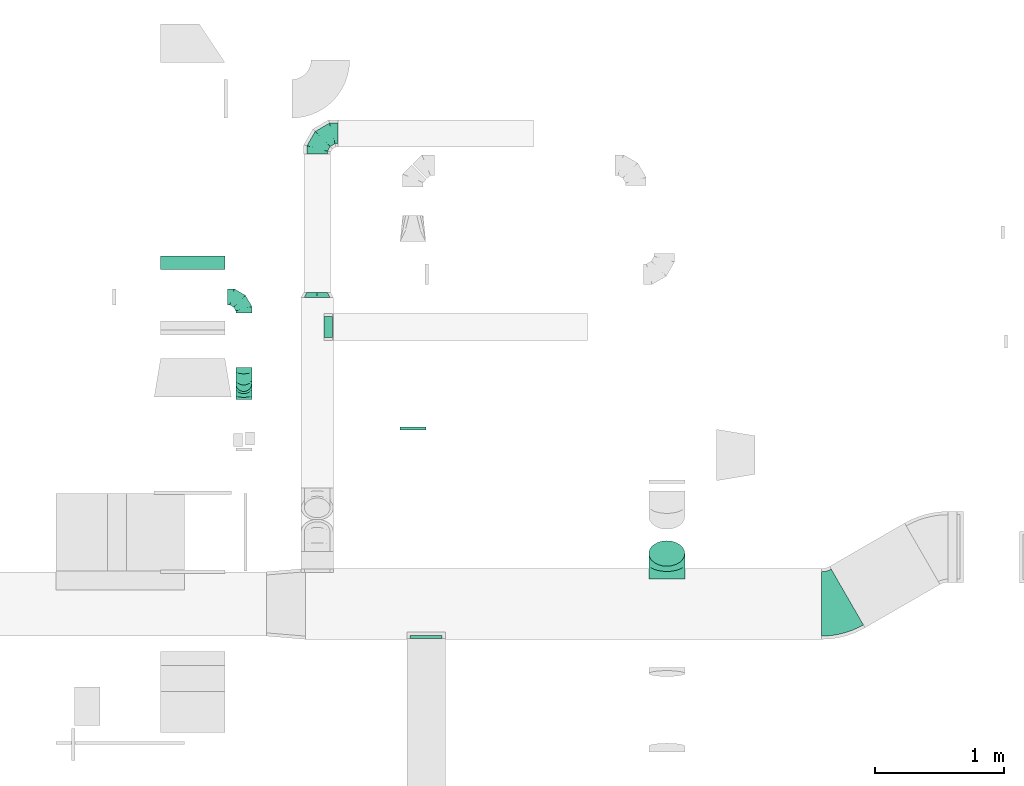
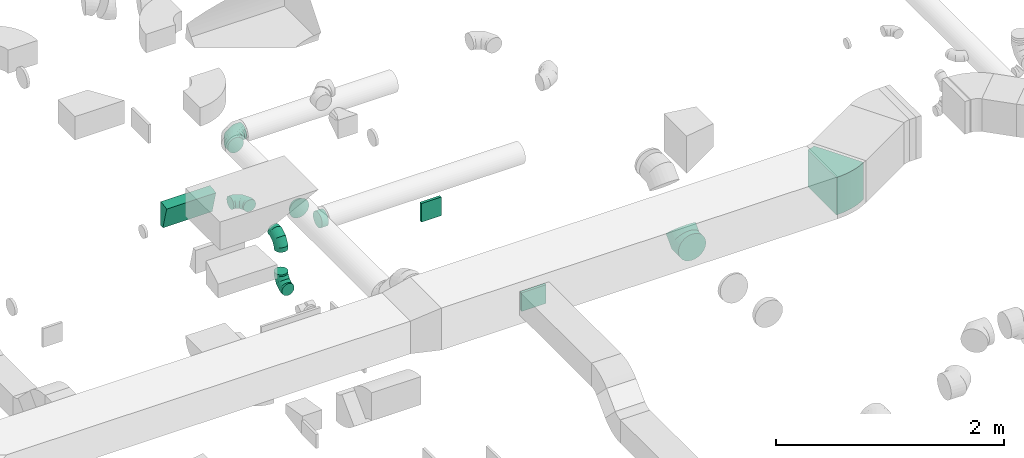
# One storey, part 43 of 62: 11 flow fittings.
"""IFC2X3 building model written with IfcOpenShell, lengths in millimetres."""

from ifc_helpers import new_model, entity, si_unit, converted_unit, derived_unit, direction, frame, frame_2d, origin, origin_2d_with_axis, place, context, subcontext, project, spatial, polyline, circle_curve, parameter, trimmed, segment, composite_curve, rectangle, outline, extrude, faceted_brep, source, transform, mapped, material, type_object, type_shapes, element, save


model = new_model("IFC2X3")

# Units and contexts
model_context = context("Model", 3, precision=0.01, world=origin(), true_north=direction((6.12303176911189e-17, 1.0)))
body_context = subcontext(model_context, "Body", "Model", "MODEL_VIEW")
ifc_project = project(units=[si_unit("LENGTHUNIT", "METRE", prefix="MILLI"), si_unit("AREAUNIT", "SQUARE_METRE"), si_unit("VOLUMEUNIT", "CUBIC_METRE"), converted_unit("PLANEANGLEUNIT", "DEGREE", entity("IfcRatioMeasure", 0.0174532925199433), si_unit("PLANEANGLEUNIT", "RADIAN"), dimensions=[0, 0, 0, 0, 0, 0, 0]), si_unit("MASSUNIT", "GRAM", prefix="KILO"), derived_unit("MASSDENSITYUNIT", [(si_unit("MASSUNIT", "GRAM", prefix="KILO"), 1), (si_unit("LENGTHUNIT", "METRE"), -3)]), derived_unit("MOMENTOFINERTIAUNIT", [(si_unit("LENGTHUNIT", "METRE"), 4)]), si_unit("TIMEUNIT", "SECOND"), si_unit("FREQUENCYUNIT", "HERTZ"), si_unit("THERMODYNAMICTEMPERATUREUNIT", "DEGREE_CELSIUS"), derived_unit("THERMALTRANSMITTANCEUNIT", [(si_unit("MASSUNIT", "GRAM", prefix="KILO"), 1), (si_unit("THERMODYNAMICTEMPERATUREUNIT", "KELVIN"), -1), (si_unit("TIMEUNIT", "SECOND"), -3)]), derived_unit("VOLUMETRICFLOWRATEUNIT", [(si_unit("LENGTHUNIT", "METRE"), 3), (si_unit("TIMEUNIT", "SECOND"), -1)]), derived_unit("MASSFLOWRATEUNIT", [(si_unit("MASSUNIT", "GRAM", prefix="KILO"), 1), (si_unit("TIMEUNIT", "SECOND"), -1)]), derived_unit("ROTATIONALFREQUENCYUNIT", [(si_unit("TIMEUNIT", "SECOND"), -1)]), si_unit("ELECTRICCURRENTUNIT", "AMPERE"), si_unit("ELECTRICVOLTAGEUNIT", "VOLT"), si_unit("POWERUNIT", "WATT"), si_unit("FORCEUNIT", "NEWTON", prefix="KILO"), si_unit("ILLUMINANCEUNIT", "LUX"), si_unit("LUMINOUSFLUXUNIT", "LUMEN"), si_unit("LUMINOUSINTENSITYUNIT", "CANDELA"), derived_unit("USERDEFINED", [(si_unit("MASSUNIT", "GRAM", prefix="KILO"), -1), (si_unit("LENGTHUNIT", "METRE"), -2), (si_unit("TIMEUNIT", "SECOND"), 3), (si_unit("LUMINOUSFLUXUNIT", "LUMEN"), 1)]), derived_unit("LINEARVELOCITYUNIT", [(si_unit("LENGTHUNIT", "METRE"), 1), (si_unit("TIMEUNIT", "SECOND"), -1)]), si_unit("PRESSUREUNIT", "PASCAL"), derived_unit("USERDEFINED", [(si_unit("LENGTHUNIT", "METRE"), -2), (si_unit("MASSUNIT", "GRAM", prefix="KILO"), 1), (si_unit("TIMEUNIT", "SECOND"), -2)]), derived_unit("LINEARFORCEUNIT", [(si_unit("MASSUNIT", "GRAM", prefix="KILO"), 1), (si_unit("LENGTHUNIT", "METRE"), 1), (si_unit("TIMEUNIT", "SECOND"), -2), (si_unit("LENGTHUNIT", "METRE"), -1)]), derived_unit("PLANARFORCEUNIT", [(si_unit("MASSUNIT", "GRAM", prefix="KILO"), 1), (si_unit("LENGTHUNIT", "METRE"), 1), (si_unit("TIMEUNIT", "SECOND"), -2), (si_unit("LENGTHUNIT", "METRE"), -2)])], contexts=[model_context])

# Site, building, storey
site_placement = place(None, origin())
site = spatial("IfcSite", under=ifc_project, at=site_placement, CompositionType="ELEMENT")
building_placement = place(site_placement, origin())
building = spatial("IfcBuilding", under=site, at=building_placement, CompositionType="ELEMENT")
storey_placement = place(building_placement, frame((0.0, 0.0, 24000.0)))
storey = spatial("IfcBuildingStorey", under=building, at=storey_placement, CompositionType="ELEMENT", Elevation=24000.0)

# Flow fittings
ifc_material = material()
duct_fitting_type_1 = type_object("IfcDuctFittingType", PredefinedType="NOTDEFINED", material=ifc_material)
shared_shape_1 = source(origin(), body_context, "Body", "SweptSolid", [
    extrude(rectangle(XDim=26.096000000009, YDim=250.0, at=origin_2d_with_axis()), frame((6.95, 0.0, -100.0)), (0.0, 0.0, 1.0), 200.0),
])
type_shapes(duct_fitting_type_1, [shared_shape_1])
flow_fitting_1_placement = place(storey_placement, frame((55179.59, 8674.98, 3550.0), z_axis=(0.0, 0.0, -1.0), x_axis=(0.0, -1.0, 0.0)))
element("IfcFlowFitting", 1, at=flow_fitting_1_placement, inside=storey, type_object=duct_fitting_type_1, material=ifc_material, context=body_context, shape_type="MappedRepresentation", body=[
    mapped(shared_shape_1, transform((0.0, 0.0, 0.0), scale=1.0)),
])
duct_fitting_type_2 = type_object("IfcDuctFittingType", PredefinedType="NOTDEFINED", material=ifc_material)
shared_shape_2 = source(origin(), body_context, "Body", "SweptSolid", [
    extrude(rectangle(XDim=200.0, YDim=26.0960000001364, at=origin_2d_with_axis()), frame((6.95, 0.0, -100.0), z_axis=(0.0, 0.0, 1.0), x_axis=(0.0, -1.0, 0.0)), (0.0, 0.0, 1.0), 200.0),
])
type_shapes(duct_fitting_type_2, [shared_shape_2])
flow_fitting_2_placement = place(storey_placement, frame((55077.37, 10282.41, 3550.0), z_axis=(0.0, 0.0, -1.0), x_axis=(0.0, 1.0, 0.0)))
element("IfcFlowFitting", 2, at=flow_fitting_2_placement, inside=storey, type_object=duct_fitting_type_2, material=ifc_material, context=body_context, shape_type="MappedRepresentation", body=[
    mapped(shared_shape_2, transform((0.0, 0.0, 0.0), scale=1.0)),
])
duct_fitting_type_3 = type_object("IfcDuctFittingType", PredefinedType="NOTDEFINED", material=ifc_material)
shared_shape_3 = source(origin(), body_context, "Body", "Brep", [
    faceted_brep([(-160.0, 0.0, -80.0), (-160.0, -20.71, -77.27), (-160.0, -40.0, -69.28), (-160.0, -56.57, -56.57), (-160.0, -69.28, -40.0), (-160.0, -77.27, -20.71), (-160.0, -80.0, 0.0), (-160.0, -77.27, 20.71), (-160.0, -69.28, 40.0), (-160.0, -56.57, 56.57), (-160.0, -40.0, 69.28), (-160.0, -20.71, 77.27), (-160.0, 0.0, 80.0), (-160.0, 20.71, 77.27), (-160.0, 40.0, 69.28), (-160.0, 56.57, 56.57), (-160.0, 69.28, 40.0), (-160.0, 77.27, 20.71), (-160.0, 80.0, 0.0), (-160.0, 77.27, -20.71), (-160.0, 69.28, -40.0), (-160.0, 56.57, -56.57), (-160.0, 40.0, -69.28), (-160.0, 20.71, -77.27), (-122.68, 20.71, 77.27), (-127.85, 40.0, 69.28), (-117.13, 0.0, 80.0), (-132.29, 56.57, 56.57), (-137.83, 77.27, 20.71), (-138.56, 80.0, 0.0), (-135.69, 69.28, 40.0), (-135.69, 69.28, -40.0), (-132.29, 56.57, -56.57), (-137.83, 77.27, -20.71), (-122.68, 20.71, -77.27), (-117.13, 0.0, -80.0), (-127.85, 40.0, -69.28), (-111.58, -20.71, -77.27), (-106.41, -40.0, -69.28), (-101.97, -56.57, -56.57), (-98.56, -69.28, -40.0), (-96.42, -77.27, -20.71), (-95.69, -80.0, 0.0), (-96.42, -77.27, 20.71), (-98.56, -69.28, 40.0), (-101.97, -56.57, 56.57), (-106.41, -40.0, 69.28), (-111.58, -20.71, 77.27), (-58.03, 58.03, 77.27), (-72.15, 72.15, 69.28), (-42.87, 42.87, 80.0), (-84.28, 84.28, 56.57), (-93.59, 93.59, 40.0), (-99.44, 99.44, 20.71), (-101.44, 101.44, 0.0), (-99.44, 99.44, -20.71), (-93.59, 93.59, -40.0), (-84.28, 84.28, -56.57), (-58.03, 58.03, -77.27), (-42.87, 42.87, -80.0), (-72.15, 72.15, -69.28), (-27.71, 27.71, -77.27), (-13.59, 13.59, -69.28), (-1.46, 1.46, -56.57), (7.85, -7.85, -40.0), (13.7, -13.7, -20.71), (15.69, -15.69, 0.0), (13.7, -13.7, 20.71), (7.85, -7.85, 40.0), (-1.46, 1.46, 56.57), (-13.59, 13.59, 69.28), (-27.71, 27.71, 77.27), (-20.71, 122.68, 77.27), (-40.0, 127.85, 69.28), (0.0, 117.13, 80.0), (-56.57, 132.29, 56.57), (-69.28, 135.69, 40.0), (-77.27, 137.83, 20.71), (-80.0, 138.56, 0.0), (-77.27, 137.83, -20.71), (-69.28, 135.69, -40.0), (-56.57, 132.29, -56.57), (-20.71, 122.68, -77.27), (0.0, 117.13, -80.0), (-40.0, 127.85, -69.28), (20.71, 111.58, -77.27), (40.0, 106.41, -69.28), (56.57, 101.97, -56.57), (69.28, 98.56, -40.0), (77.27, 96.42, -20.71), (80.0, 95.69, 0.0), (77.27, 96.42, 20.71), (69.28, 98.56, 40.0), (56.57, 101.97, 56.57), (40.0, 106.41, 69.28), (20.71, 111.58, 77.27), (-20.71, 160.0, -77.27), (-40.0, 160.0, -69.28), (-56.57, 160.0, -56.57), (-69.28, 160.0, -40.0), (-77.27, 160.0, -20.71), (-80.0, 160.0, 0.0), (-77.27, 160.0, 20.71), (-69.28, 160.0, 40.0), (-56.57, 160.0, 56.57), (-40.0, 160.0, 69.28), (-20.71, 160.0, 77.27), (0.0, 160.0, 80.0), (20.71, 160.0, 77.27), (40.0, 160.0, 69.28), (56.57, 160.0, 56.57), (69.28, 160.0, 40.0), (77.27, 160.0, 20.71), (80.0, 160.0, 0.0), (77.27, 160.0, -20.71), (69.28, 160.0, -40.0), (56.57, 160.0, -56.57), (40.0, 160.0, -69.28), (20.71, 160.0, -77.27), (0.0, 160.0, -80.0)], [[[0, 1, 2, 3, 4, 5, 6, 7, 8, 9, 10, 11, 12, 13, 14, 15, 16, 17, 18, 19, 20, 21, 22, 23]], [[24, 25, 14, 13]], [[26, 24, 13, 12]], [[14, 25, 27, 15]], [[28, 29, 18, 17]], [[30, 28, 17, 16]], [[15, 27, 30, 16]], [[20, 31, 32, 21]], [[33, 31, 20, 19]], [[18, 29, 33, 19]], [[34, 35, 0, 23]], [[36, 34, 23, 22]], [[32, 36, 22, 21]], [[1, 0, 35, 37]], [[2, 1, 37, 38]], [[3, 2, 38, 39]], [[5, 4, 40, 41]], [[6, 5, 41, 42]], [[39, 40, 4, 3]], [[6, 42, 43, 7]], [[7, 43, 44, 8]], [[8, 44, 45, 9]], [[9, 45, 46, 10]], [[10, 46, 47, 11]], [[26, 12, 11, 47]], [[48, 49, 25, 24]], [[50, 48, 24, 26]], [[27, 25, 49, 51]], [[52, 53, 28, 30]], [[51, 52, 30, 27]], [[29, 28, 53, 54]], [[55, 56, 31, 33]], [[54, 55, 33, 29]], [[32, 31, 56, 57]], [[58, 59, 35, 34]], [[60, 58, 34, 36]], [[57, 60, 36, 32]], [[37, 35, 59, 61]], [[38, 37, 61, 62]], [[39, 38, 62, 63]], [[41, 40, 64, 65]], [[42, 41, 65, 66]], [[63, 64, 40, 39]], [[43, 42, 66, 67]], [[44, 43, 67, 68]], [[68, 69, 45, 44]], [[46, 45, 69, 70]], [[47, 46, 70, 71]], [[26, 47, 71, 50]], [[72, 73, 49, 48]], [[74, 72, 48, 50]], [[51, 49, 73, 75]], [[76, 77, 53, 52]], [[75, 76, 52, 51]], [[54, 53, 77, 78]], [[79, 80, 56, 55]], [[78, 79, 55, 54]], [[57, 56, 80, 81]], [[82, 83, 59, 58]], [[84, 82, 58, 60]], [[81, 84, 60, 57]], [[61, 59, 83, 85]], [[62, 61, 85, 86]], [[63, 62, 86, 87]], [[65, 64, 88, 89]], [[66, 65, 89, 90]], [[87, 88, 64, 63]], [[67, 66, 90, 91]], [[68, 67, 91, 92]], [[92, 93, 69, 68]], [[70, 69, 93, 94]], [[71, 70, 94, 95]], [[50, 71, 95, 74]], [[96, 97, 98, 99, 100, 101, 102, 103, 104, 105, 106, 107, 108, 109, 110, 111, 112, 113, 114, 115, 116, 117, 118, 119]], [[72, 74, 107, 106]], [[73, 72, 106, 105]], [[75, 73, 105, 104]], [[77, 76, 103, 102]], [[78, 77, 102, 101]], [[75, 104, 103, 76]], [[78, 101, 100, 79]], [[79, 100, 99, 80]], [[80, 99, 98, 81]], [[84, 97, 96, 82]], [[82, 96, 119, 83]], [[84, 81, 98, 97]], [[118, 117, 86, 85]], [[119, 118, 85, 83]], [[116, 87, 86, 117]], [[88, 115, 114, 89]], [[89, 114, 113, 90]], [[115, 88, 87, 116]], [[112, 111, 92, 91]], [[113, 112, 91, 90]], [[111, 110, 93, 92]], [[95, 94, 109, 108]], [[74, 95, 108, 107]], [[110, 109, 94, 93]]]),
])
type_shapes(duct_fitting_type_3, [shared_shape_3])
flow_fitting_3_placement = place(storey_placement, frame((54333.52, 12582.77, 3200.0), z_axis=(0.0, 0.0, 1.0), x_axis=(-1.0, 0.0, 0.0)))
element("IfcFlowFitting", 3, at=flow_fitting_3_placement, inside=storey, type_object=duct_fitting_type_3, material=ifc_material, context=body_context, shape_type="MappedRepresentation", body=[
    mapped(shared_shape_3, transform((0.0, 0.0, 0.0), scale=1.0)),
])
duct_fitting_type_4 = type_object("IfcDuctFittingType", PredefinedType="NOTDEFINED", material=ifc_material)
shared_shape_4 = source(origin(), body_context, "Body", "Brep", [
    faceted_brep([(40.0, -58.78, -80.9), (40.0, -30.9, -95.11), (40.0, 0.0, -100.0), (40.0, 30.9, -95.11), (40.0, 58.78, -80.9), (40.0, 80.9, -58.78), (40.0, 95.11, -30.9), (40.0, 100.0, 0.0), (40.0, 95.11, 30.9), (40.0, 80.9, 58.78), (40.0, 58.78, 80.9), (40.0, 30.9, 95.11), (40.0, 0.0, 100.0), (40.0, -30.9, 95.11), (40.0, -58.78, 80.9), (40.0, -80.9, 58.78), (40.0, -95.11, 30.9), (40.0, -100.0, 0.0), (40.0, -95.11, -30.9), (40.0, -80.9, -58.78), (0.0, -30.61, -73.91), (0.0, -43.59, -65.24), (0.0, -56.57, -56.57), (0.0, -65.24, -43.59), (0.0, -73.91, -30.61), (0.0, -76.96, -15.31), (0.0, -80.0, 0.0), (0.0, -76.96, 15.31), (0.0, -73.91, 30.61), (0.0, -65.24, 43.59), (0.0, -56.57, 56.57), (0.0, -43.59, 65.24), (0.0, -30.61, 73.91), (0.0, -15.31, 76.96), (0.0, 0.0, 80.0), (0.0, 15.31, 76.96), (0.0, 30.61, 73.91), (0.0, 43.59, 65.24), (0.0, 56.57, 56.57), (0.0, 65.24, 43.59), (0.0, 73.91, 30.61), (0.0, 76.96, 15.31), (0.0, 80.0, 0.0), (0.0, 76.96, -15.31), (0.0, 73.91, -30.61), (0.0, 65.24, -43.59), (0.0, 56.57, -56.57), (0.0, 43.59, -65.24), (0.0, 30.61, -73.91), (0.0, 15.31, -76.96), (0.0, 0.0, -80.0), (0.0, -15.31, -76.96)], [[[0, 1, 2, 3, 4, 5, 6, 7, 8, 9, 10, 11, 12, 13, 14, 15, 16, 17, 18, 19]], [[20, 21, 22, 23, 24, 25, 26, 27, 28, 29, 30, 31, 32, 33, 34, 35, 36, 37, 38, 39, 40, 41, 42, 43, 44, 45, 46, 47, 48, 49, 50, 51]], [[7, 41, 8]], [[40, 9, 8]], [[10, 38, 37, 36]], [[39, 38, 9, 40]], [[11, 36, 35]], [[34, 12, 35]], [[41, 40, 8]], [[10, 36, 11]], [[35, 12, 11]], [[41, 7, 42]], [[38, 10, 9]], [[12, 33, 13]], [[32, 14, 13]], [[15, 30, 29, 28]], [[31, 30, 14, 32]], [[16, 28, 27]], [[26, 17, 27]], [[33, 32, 13]], [[15, 28, 16]], [[27, 17, 16]], [[33, 12, 34]], [[30, 15, 14]], [[17, 25, 18]], [[24, 19, 18]], [[0, 22, 21, 20]], [[23, 22, 19, 24]], [[1, 20, 51]], [[50, 2, 51]], [[25, 24, 18]], [[0, 20, 1]], [[51, 2, 1]], [[25, 17, 26]], [[22, 0, 19]], [[2, 49, 3]], [[48, 4, 3]], [[5, 46, 45, 44]], [[47, 46, 4, 48]], [[6, 44, 43]], [[42, 7, 43]], [[49, 48, 3]], [[5, 44, 6]], [[43, 7, 6]], [[49, 2, 50]], [[46, 5, 4]]]),
])
type_shapes(duct_fitting_type_4, [shared_shape_4])
flow_fitting_4_placement = place(storey_placement, frame((54333.52, 11347.77, 3200.0), z_axis=(0.0, 0.0, 1.0), x_axis=(0.0, -1.0, 0.0)))
element("IfcFlowFitting", 4, at=flow_fitting_4_placement, inside=storey, type_object=duct_fitting_type_4, material=ifc_material, context=body_context, shape_type="MappedRepresentation", body=[
    mapped(shared_shape_4, transform((0.0, 0.0, 0.0), scale=1.0)),
])
duct_fitting_type_5 = type_object("IfcDuctFittingType", PredefinedType="NOTDEFINED", material=ifc_material)
shared_shape_5 = source(origin(), body_context, "Body", "Brep", [
    faceted_brep([(-125.0, 0.0, -62.5), (-125.0, -16.18, -60.37), (-125.0, -31.25, -54.13), (-125.0, -44.19, -44.19), (-125.0, -54.13, -31.25), (-125.0, -60.37, -16.18), (-125.0, -62.5, 0.0), (-125.0, -60.37, 16.18), (-125.0, -54.13, 31.25), (-125.0, -44.19, 44.19), (-125.0, -31.25, 54.13), (-125.0, -16.18, 60.37), (-125.0, 0.0, 62.5), (-125.0, 16.18, 60.37), (-125.0, 31.25, 54.13), (-125.0, 44.19, 44.19), (-125.0, 54.13, 31.25), (-125.0, 60.37, 16.18), (-125.0, 62.5, 0.0), (-125.0, 60.37, -16.18), (-125.0, 54.13, -31.25), (-125.0, 44.19, -44.19), (-125.0, 31.25, -54.13), (-125.0, 16.18, -60.37), (-95.84, 16.18, 60.37), (-99.88, 31.25, 54.13), (-91.51, 0.0, 62.5), (-103.35, 44.19, 44.19), (-107.68, 60.37, 16.18), (-108.25, 62.5, 0.0), (-106.01, 54.13, 31.25), (-106.01, 54.13, -31.25), (-103.35, 44.19, -44.19), (-107.68, 60.37, -16.18), (-95.84, 16.18, -60.37), (-91.51, 0.0, -62.5), (-99.88, 31.25, -54.13), (-87.17, -16.18, -60.37), (-83.13, -31.25, -54.13), (-79.66, -44.19, -44.19), (-77.0, -54.13, -31.25), (-75.33, -60.37, -16.18), (-74.76, -62.5, 0.0), (-75.33, -60.37, 16.18), (-77.0, -54.13, 31.25), (-79.66, -44.19, 44.19), (-83.13, -31.25, 54.13), (-87.17, -16.18, 60.37), (-45.34, 45.34, 60.37), (-56.37, 56.37, 54.13), (-33.49, 33.49, 62.5), (-65.85, 65.85, 44.19), (-73.12, 73.12, 31.25), (-77.69, 77.69, 16.18), (-79.25, 79.25, 0.0), (-77.69, 77.69, -16.18), (-73.12, 73.12, -31.25), (-65.85, 65.85, -44.19), (-45.34, 45.34, -60.37), (-33.49, 33.49, -62.5), (-56.37, 56.37, -54.13), (-21.65, 21.65, -60.37), (-10.62, 10.62, -54.13), (-1.14, 1.14, -44.19), (6.13, -6.13, -31.25), (10.7, -10.7, -16.18), (12.26, -12.26, 0.0), (10.7, -10.7, 16.18), (6.13, -6.13, 31.25), (-1.14, 1.14, 44.19), (-10.62, 10.62, 54.13), (-21.65, 21.65, 60.37), (-16.18, 95.84, 60.37), (-31.25, 99.88, 54.13), (0.0, 91.51, 62.5), (-44.19, 103.35, 44.19), (-54.13, 106.01, 31.25), (-60.37, 107.68, 16.18), (-62.5, 108.25, 0.0), (-60.37, 107.68, -16.18), (-54.13, 106.01, -31.25), (-44.19, 103.35, -44.19), (-16.18, 95.84, -60.37), (0.0, 91.51, -62.5), (-31.25, 99.88, -54.13), (16.18, 87.17, -60.37), (31.25, 83.13, -54.13), (44.19, 79.66, -44.19), (54.13, 77.0, -31.25), (60.37, 75.33, -16.18), (62.5, 74.76, 0.0), (60.37, 75.33, 16.18), (54.13, 77.0, 31.25), (44.19, 79.66, 44.19), (31.25, 83.13, 54.13), (16.18, 87.17, 60.37), (-16.18, 125.0, -60.37), (-31.25, 125.0, -54.13), (-44.19, 125.0, -44.19), (-54.13, 125.0, -31.25), (-60.37, 125.0, -16.18), (-62.5, 125.0, 0.0), (-60.37, 125.0, 16.18), (-54.13, 125.0, 31.25), (-44.19, 125.0, 44.19), (-31.25, 125.0, 54.13), (-16.18, 125.0, 60.37), (0.0, 125.0, 62.5), (16.18, 125.0, 60.37), (31.25, 125.0, 54.13), (44.19, 125.0, 44.19), (54.13, 125.0, 31.25), (60.37, 125.0, 16.18), (62.5, 125.0, 0.0), (60.37, 125.0, -16.18), (54.13, 125.0, -31.25), (44.19, 125.0, -44.19), (31.25, 125.0, -54.13), (16.18, 125.0, -60.37), (0.0, 125.0, -62.5)], [[[0, 1, 2, 3, 4, 5, 6, 7, 8, 9, 10, 11, 12, 13, 14, 15, 16, 17, 18, 19, 20, 21, 22, 23]], [[24, 25, 14, 13]], [[26, 24, 13, 12]], [[14, 25, 27, 15]], [[28, 29, 18, 17]], [[30, 28, 17, 16]], [[15, 27, 30, 16]], [[20, 31, 32, 21]], [[33, 31, 20, 19]], [[18, 29, 33, 19]], [[34, 35, 0, 23]], [[36, 34, 23, 22]], [[21, 32, 36, 22]], [[1, 0, 35, 37]], [[2, 1, 37, 38]], [[38, 39, 3, 2]], [[5, 4, 40, 41]], [[6, 5, 41, 42]], [[39, 40, 4, 3]], [[6, 42, 43, 7]], [[7, 43, 44, 8]], [[45, 9, 8, 44]], [[9, 45, 46, 10]], [[10, 46, 47, 11]], [[26, 12, 11, 47]], [[48, 49, 25, 24]], [[50, 48, 24, 26]], [[27, 25, 49, 51]], [[52, 53, 28, 30]], [[51, 52, 30, 27]], [[29, 28, 53, 54]], [[55, 56, 31, 33]], [[54, 55, 33, 29]], [[57, 32, 31, 56]], [[58, 59, 35, 34]], [[60, 58, 34, 36]], [[57, 60, 36, 32]], [[37, 35, 59, 61]], [[38, 37, 61, 62]], [[39, 38, 62, 63]], [[41, 40, 64, 65]], [[42, 41, 65, 66]], [[63, 64, 40, 39]], [[43, 42, 66, 67]], [[44, 43, 67, 68]], [[68, 69, 45, 44]], [[46, 45, 69, 70]], [[47, 46, 70, 71]], [[26, 47, 71, 50]], [[72, 73, 49, 48]], [[74, 72, 48, 50]], [[51, 49, 73, 75]], [[76, 77, 53, 52]], [[75, 76, 52, 51]], [[54, 53, 77, 78]], [[79, 80, 56, 55]], [[78, 79, 55, 54]], [[81, 57, 56, 80]], [[82, 83, 59, 58]], [[84, 82, 58, 60]], [[81, 84, 60, 57]], [[61, 59, 83, 85]], [[62, 61, 85, 86]], [[63, 62, 86, 87]], [[65, 64, 88, 89]], [[66, 65, 89, 90]], [[87, 88, 64, 63]], [[67, 66, 90, 91]], [[68, 67, 91, 92]], [[92, 93, 69, 68]], [[70, 69, 93, 94]], [[71, 70, 94, 95]], [[50, 71, 95, 74]], [[96, 97, 98, 99, 100, 101, 102, 103, 104, 105, 106, 107, 108, 109, 110, 111, 112, 113, 114, 115, 116, 117, 118, 119]], [[72, 74, 107, 106]], [[73, 72, 106, 105]], [[75, 73, 105, 104]], [[77, 76, 103, 102]], [[78, 77, 102, 101]], [[75, 104, 103, 76]], [[78, 101, 100, 79]], [[79, 100, 99, 80]], [[80, 99, 98, 81]], [[96, 119, 83, 82]], [[97, 96, 82, 84]], [[84, 81, 98, 97]], [[83, 119, 118, 85]], [[85, 118, 117, 86]], [[116, 87, 86, 117]], [[88, 115, 114, 89]], [[89, 114, 113, 90]], [[115, 88, 87, 116]], [[91, 90, 113, 112]], [[92, 91, 112, 111]], [[111, 110, 93, 92]], [[95, 94, 109, 108]], [[74, 95, 108, 107]], [[110, 109, 94, 93]]]),
])
type_shapes(duct_fitting_type_5, [shared_shape_5])
for number, where, z_axis, x_axis in (
    (5, (53762.73, 10639.17, 3010.0), (1.0, 0.0, 0.0), (0.0, 1.0, 0.0)),
    (6, (53762.73, 10639.17, 3500.0), (-1.0, 0.0, 0.0), (0.0, 0.0, 1.0)),
    (7, (53762.73, 11312.1, 3500.0), (0.0, 0.0, 1.0), (0.0, 1.0, 0.0)),
):
    element("IfcFlowFitting", number, at=place(storey_placement, frame(where, z_axis=z_axis, x_axis=x_axis)), inside=storey, type_object=duct_fitting_type_5, material=ifc_material, context=body_context, shape_type="MappedRepresentation", body=[
        mapped(shared_shape_5, transform((0.0, 0.0, 0.0), scale=1.0)),
    ])
duct_fitting_type_6 = type_object("IfcDuctFittingType", PredefinedType="NOTDEFINED", material=ifc_material)
shared_shape_6 = source(origin(), body_context, "Body", "Brep", [
    faceted_brep([(20.0, 0.0, -80.0), (20.0, 20.71, -77.27), (20.0, 40.0, -69.28), (20.0, 56.57, -56.57), (20.0, 69.28, -40.0), (20.0, 77.27, -20.71), (20.0, 80.0, 0.0), (20.0, 77.27, 20.71), (20.0, 69.28, 40.0), (20.0, 56.57, 56.57), (20.0, 40.0, 69.28), (20.0, 20.71, 77.27), (20.0, 0.0, 80.0), (20.0, -20.71, 77.27), (20.0, -40.0, 69.28), (20.0, -56.57, 56.57), (20.0, -69.28, 40.0), (20.0, -77.27, 20.71), (20.0, -80.0, 0.0), (20.0, -77.27, -20.71), (20.0, -69.28, -40.0), (20.0, -56.57, -56.57), (20.0, -40.0, -69.28), (20.0, -20.71, -77.27), (0.0, 0.0, 80.0), (-46.1, 0.0, 80.0), (-46.1, -20.71, 77.27), (0.0, -20.71, 77.27), (-46.1, -40.0, 69.28), (0.0, -40.0, 69.28), (0.0, -56.57, 56.57), (-46.1, -56.57, 56.57), (0.0, -69.28, 40.0), (-46.1, -69.28, 40.0), (-46.1, -77.27, 20.71), (0.0, -77.27, 20.71), (-46.1, -80.0, 0.0), (0.0, -80.0, 0.0), (-46.1, -77.27, -20.71), (0.0, -77.27, -20.71), (-46.1, -69.28, -40.0), (0.0, -69.28, -40.0), (0.0, -56.57, -56.57), (-46.1, -56.57, -56.57), (0.0, -40.0, -69.28), (-46.1, -40.0, -69.28), (-46.1, -20.71, -77.27), (0.0, -20.71, -77.27), (-46.1, 0.0, -80.0), (0.0, 0.0, -80.0), (-46.1, 20.71, -77.27), (0.0, 20.71, -77.27), (-46.1, 40.0, -69.28), (0.0, 40.0, -69.28), (0.0, 56.57, -56.57), (-46.1, 56.57, -56.57), (0.0, 69.28, -40.0), (-46.1, 69.28, -40.0), (-46.1, 77.27, -20.71), (0.0, 77.27, -20.71), (-46.1, 80.0, 0.0), (0.0, 80.0, 0.0), (-46.1, 77.27, 20.71), (0.0, 77.27, 20.71), (-46.1, 69.28, 40.0), (0.0, 69.28, 40.0), (0.0, 56.57, 56.57), (-46.1, 56.57, 56.57), (0.0, 40.0, 69.28), (-46.1, 40.0, 69.28), (-46.1, 20.71, 77.27), (0.0, 20.71, 77.27)], [[[0, 1, 2, 3, 4, 5, 6, 7, 8, 9, 10, 11, 12, 13, 14, 15, 16, 17, 18, 19, 20, 21, 22, 23]], [[13, 12, 24, 25, 26, 27]], [[14, 13, 27, 26, 28, 29]], [[30, 15, 14, 29, 28, 31]], [[17, 16, 32, 33, 34, 35]], [[18, 17, 35, 34, 36, 37]], [[32, 16, 15, 30, 31, 33]], [[19, 18, 37, 36, 38, 39]], [[20, 19, 39, 38, 40, 41]], [[42, 21, 20, 41, 40, 43]], [[23, 22, 44, 45, 46, 47]], [[0, 23, 47, 46, 48, 49]], [[44, 22, 21, 42, 43, 45]], [[1, 0, 49, 48, 50, 51]], [[2, 1, 51, 50, 52, 53]], [[54, 3, 2, 53, 52, 55]], [[5, 4, 56, 57, 58, 59]], [[6, 5, 59, 58, 60, 61]], [[56, 4, 3, 54, 55, 57]], [[7, 6, 61, 60, 62, 63]], [[8, 7, 63, 62, 64, 65]], [[66, 9, 8, 65, 64, 67]], [[11, 10, 68, 69, 70, 71]], [[12, 11, 71, 70, 25, 24]], [[68, 10, 9, 66, 67, 69]], [[46, 45, 43, 40, 38, 36, 34, 33, 31, 28, 26, 25, 70, 69, 67, 64, 62, 60, 58, 57, 55, 52, 50, 48]]]),
])
type_shapes(duct_fitting_type_6, [shared_shape_6])
flow_fitting_5_placement = place(storey_placement, frame((54433.52, 11077.82, 3200.0), z_axis=(0.0, 0.0, -1.0), x_axis=(1.0, 0.0, 0.0)))
element("IfcFlowFitting", 8, at=flow_fitting_5_placement, inside=storey, type_object=duct_fitting_type_6, material=ifc_material, context=body_context, shape_type="MappedRepresentation", body=[
    mapped(shared_shape_6, transform((0.0, 0.0, 0.0), scale=1.0)),
])
duct_fitting_type_7 = type_object("IfcDuctFittingType", PredefinedType="NOTDEFINED", material=ifc_material)
shared_shape_7 = source(origin(), body_context, "Body", "Brep", [
    faceted_brep([(-115.98, 0.0, -140.0), (-115.98, -36.23, -135.23), (-115.98, -70.0, -121.24), (-115.98, -98.99, -98.99), (-115.98, -121.24, -70.0), (-115.98, -135.23, -36.23), (-115.98, -140.0, 0.0), (-115.98, -135.23, 36.23), (-115.98, -121.24, 70.0), (-115.98, -98.99, 98.99), (-115.98, -70.0, 121.24), (-115.98, -36.23, 135.23), (-115.98, 0.0, 140.0), (-115.98, 36.23, 135.23), (-115.98, 70.0, 121.24), (-115.98, 98.99, 98.99), (-115.98, 121.24, 70.0), (-115.98, 135.23, 36.23), (-115.98, 140.0, 0.0), (-115.98, 135.23, -36.23), (-115.98, 121.24, -70.0), (-115.98, 98.99, -98.99), (-115.98, 70.0, -121.24), (-115.98, 36.23, -135.23), (-15.01, 36.23, 135.23), (-28.99, 70.0, 121.24), (0.0, 0.0, 140.0), (-41.01, 98.99, 98.99), (-56.01, 135.23, 36.23), (-57.99, 140.0, 0.0), (-50.22, 121.24, 70.0), (-50.22, 121.24, -70.0), (-41.01, 98.99, -98.99), (-56.01, 135.23, -36.23), (-15.01, 36.23, -135.23), (0.0, 0.0, -140.0), (-28.99, 70.0, -121.24), (15.01, -36.23, -135.23), (28.99, -70.0, -121.24), (41.01, -98.99, -98.99), (50.22, -121.24, -70.0), (56.01, -135.23, -36.23), (57.99, -140.0, 0.0), (56.01, -135.23, 36.23), (50.22, -121.24, 70.0), (41.01, -98.99, 98.99), (28.99, -70.0, 121.24), (15.01, -36.23, 135.23), (82.01, 82.01, 140.0), (56.39, 107.63, 135.23), (32.51, 131.51, 121.24), (12.01, 152.01, 98.99), (-3.72, 167.74, 70.0), (-13.61, 177.63, 36.23), (-16.98, 181.01, 0.0), (-13.61, 177.63, -36.23), (-3.72, 167.74, -70.0), (12.01, 152.01, -98.99), (32.51, 131.51, -121.24), (56.39, 107.63, -135.23), (82.01, 82.01, -140.0), (107.63, 56.39, -135.23), (131.51, 32.51, -121.24), (152.01, 12.01, -98.99), (167.74, -3.72, -70.0), (177.63, -13.61, -36.23), (181.01, -16.98, 0.0), (177.63, -13.61, 36.23), (167.74, -3.72, 70.0), (152.01, 12.01, 98.99), (131.51, 32.51, 121.24), (107.63, 56.39, 135.23)], [[[0, 1, 2, 3, 4, 5, 6, 7, 8, 9, 10, 11, 12, 13, 14, 15, 16, 17, 18, 19, 20, 21, 22, 23]], [[24, 25, 14, 13]], [[26, 24, 13, 12]], [[14, 25, 27, 15]], [[28, 29, 18, 17]], [[30, 28, 17, 16]], [[15, 27, 30, 16]], [[20, 31, 32, 21]], [[33, 31, 20, 19]], [[18, 29, 33, 19]], [[34, 35, 0, 23]], [[36, 34, 23, 22]], [[32, 36, 22, 21]], [[1, 0, 35, 37]], [[2, 1, 37, 38]], [[38, 39, 3, 2]], [[5, 4, 40, 41]], [[6, 5, 41, 42]], [[39, 40, 4, 3]], [[6, 42, 43, 7]], [[7, 43, 44, 8]], [[8, 44, 45, 9]], [[9, 45, 46, 10]], [[10, 46, 47, 11]], [[26, 12, 11, 47]], [[24, 26, 48, 49]], [[25, 24, 49, 50]], [[27, 25, 50, 51]], [[28, 30, 52, 53]], [[29, 28, 53, 54]], [[51, 52, 30, 27]], [[29, 54, 55, 33]], [[33, 55, 56, 31]], [[57, 32, 31, 56]], [[36, 58, 59, 34]], [[34, 59, 60, 35]], [[58, 36, 32, 57]], [[35, 60, 61, 37]], [[37, 61, 62, 38]], [[63, 39, 38, 62]], [[40, 64, 65, 41]], [[41, 65, 66, 42]], [[64, 40, 39, 63]], [[43, 42, 66, 67]], [[44, 43, 67, 68]], [[68, 69, 45, 44]], [[47, 46, 70, 71]], [[26, 47, 71, 48]], [[69, 70, 46, 45]], [[59, 58, 57, 56, 55, 54, 53, 52, 51, 50, 49, 48, 71, 70, 69, 68, 67, 66, 65, 64, 63, 62, 61, 60]]]),
])
type_shapes(duct_fitting_type_7, [shared_shape_7])
flow_fitting_6_placement = place(storey_placement, frame((57051.15, 9235.41, 3158.72), z_axis=(-1.0, 0.0, 0.0), x_axis=(0.0, -0.707106781186525, -0.70710678118657)))
element("IfcFlowFitting", 9, at=flow_fitting_6_placement, inside=storey, type_object=duct_fitting_type_7, material=ifc_material, context=body_context, shape_type="MappedRepresentation", body=[
    mapped(shared_shape_7, transform((0.0, 0.0, 0.0), scale=1.0)),
])
duct_fitting_type_8 = type_object("IfcDuctFittingType", PredefinedType="NOTDEFINED", material=ifc_material)
shared_shape_8 = source(origin(), body_context, "Body", "SweptSolid", [
    extrude(outline(composite_curve([segment(polyline([(-276.79, -100.0), (223.21, -100.0)]), True, "CONTINUOUS"), segment(trimmed(circle_curve(frame_2d((373.21, -100.0), x_axis=(-0.866025403784437, 0.499999999999998)), 150.0), [parameter(0.0)], [parameter(29.9999999999999)], True, "PARAMETER"), False, "CONTINUOUS"), segment(polyline([(243.3, -25.0), (-189.71, 225.0)]), True, "CONTINUOUS"), segment(trimmed(circle_curve(frame_2d((373.21, -100.0), x_axis=(-0.866025403784437, 0.499999999999998)), 650.0), [parameter(0.0)], [parameter(29.9999999999999)], True, "PARAMETER"), True, "CONTINUOUS")], self_intersect=False)), frame((-7.18, 26.79, -200.0), z_axis=(0.0, 0.0, 1.0), x_axis=(-0.499999999999999, 0.866025403784439, 0.0)), (0.0, 0.0, 1.0), 400.0),
])
type_shapes(duct_fitting_type_8, [shared_shape_8])
flow_fitting_7_placement = place(storey_placement, frame((58361.73, 8924.98, 3550.0)))
element("IfcFlowFitting", 10, at=flow_fitting_7_placement, inside=storey, type_object=duct_fitting_type_8, material=ifc_material, context=body_context, shape_type="MappedRepresentation", body=[
    mapped(shared_shape_8, transform((0.0, 0.0, 0.0), scale=1.0)),
])
duct_fitting_type_9 = type_object("IfcDuctFittingType", PredefinedType="NOTDEFINED", material=ifc_material)
shared_shape_9 = source(origin(), body_context, "Body", "SweptSolid", [
    extrude(outline(composite_curve([segment(polyline([(-130.02, -36.82), (119.98, -36.82)]), True, "CONTINUOUS"), segment(trimmed(circle_curve(frame_2d((269.98, -36.82), x_axis=(-0.963480255930653, 0.267779380146798)), 150.0), [parameter(0.0)], [parameter(15.5321696608975)], True, "PARAMETER"), False, "CONTINUOUS"), segment(polyline([(125.46, 3.35), (-115.41, 70.29)]), True, "CONTINUOUS"), segment(trimmed(circle_curve(frame_2d((269.98, -36.82), x_axis=(-0.963480255930653, 0.267779380146798)), 400.0), [parameter(0.0)], [parameter(15.5321696608975)], True, "PARAMETER"), True, "CONTINUOUS")], self_intersect=False)), frame((-0.68, 5.02, -250.0), z_axis=(0.0, 0.0, 1.0), x_axis=(-0.267779380146797, 0.963480255930653, 0.0)), (0.0, 0.0, 1.0), 500.0),
])
type_shapes(duct_fitting_type_9, [shared_shape_9])
flow_fitting_8_placement = place(storey_placement, frame((53365.82, 11593.04, 3375.0), z_axis=(1.0, 0.0, 0.0), x_axis=(0.0, -1.0, 0.0)))
element("IfcFlowFitting", 11, at=flow_fitting_8_placement, inside=storey, type_object=duct_fitting_type_9, material=ifc_material, context=body_context, shape_type="MappedRepresentation", body=[
    mapped(shared_shape_9, transform((0.0, 0.0, 0.0), scale=1.0)),
])

save(model, "model.ifc")
